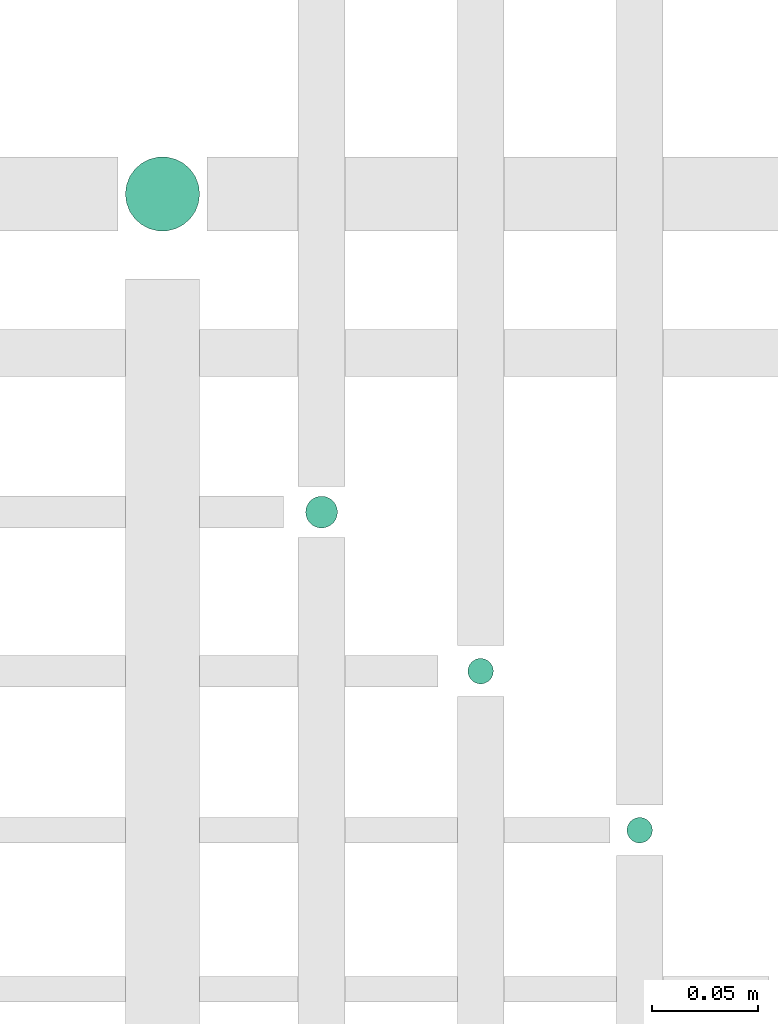
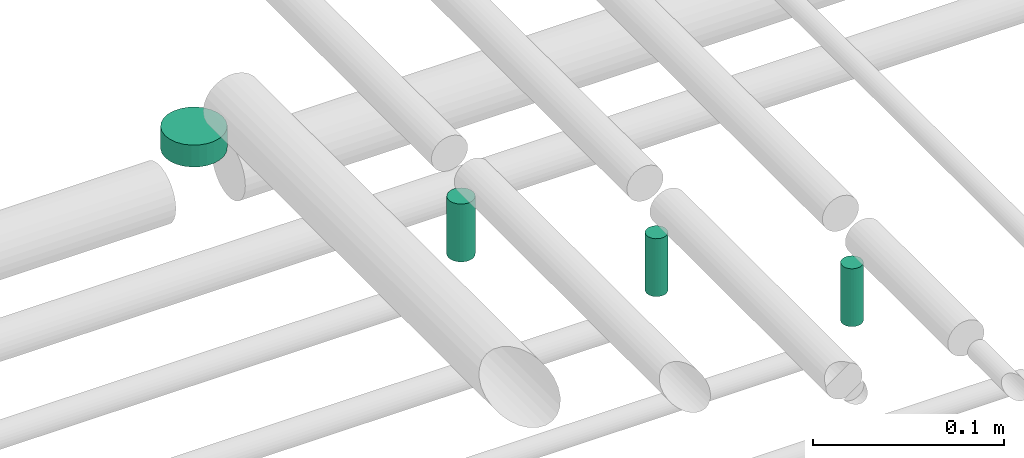
# One storey, part 60 of 65: 4 flow segments.
"""IFC2X3 building model written with IfcOpenShell, lengths in millimetres."""

from ifc_helpers import new_model, entity, si_unit, converted_unit, derived_unit, direction, frame, origin, origin_2d_with_axis, place, context, subcontext, project, spatial, circle, extrude, type_object, element, save


model = new_model("IFC2X3")

# Units and contexts
model_context = context("Model", 3, precision=0.01, world=origin(), true_north=direction((6.12303176911189e-17, 1.0)))
body_context = subcontext(model_context, "Body", "Model", "MODEL_VIEW")
ifc_project = project(units=[si_unit("LENGTHUNIT", "METRE", prefix="MILLI"), si_unit("AREAUNIT", "SQUARE_METRE"), si_unit("VOLUMEUNIT", "CUBIC_METRE"), converted_unit("PLANEANGLEUNIT", "DEGREE", entity("IfcRatioMeasure", 0.0174532925199433), si_unit("PLANEANGLEUNIT", "RADIAN"), dimensions=[0, 0, 0, 0, 0, 0, 0]), si_unit("MASSUNIT", "GRAM", prefix="KILO"), derived_unit("MASSDENSITYUNIT", [(si_unit("MASSUNIT", "GRAM", prefix="KILO"), 1), (si_unit("LENGTHUNIT", "METRE"), -3)]), derived_unit("MOMENTOFINERTIAUNIT", [(si_unit("LENGTHUNIT", "METRE"), 4)]), si_unit("TIMEUNIT", "SECOND"), si_unit("FREQUENCYUNIT", "HERTZ"), si_unit("THERMODYNAMICTEMPERATUREUNIT", "DEGREE_CELSIUS"), derived_unit("THERMALTRANSMITTANCEUNIT", [(si_unit("MASSUNIT", "GRAM", prefix="KILO"), 1), (si_unit("THERMODYNAMICTEMPERATUREUNIT", "KELVIN"), -1), (si_unit("TIMEUNIT", "SECOND"), -3)]), derived_unit("VOLUMETRICFLOWRATEUNIT", [(si_unit("LENGTHUNIT", "METRE"), 3), (si_unit("TIMEUNIT", "SECOND"), -1)]), derived_unit("MASSFLOWRATEUNIT", [(si_unit("MASSUNIT", "GRAM", prefix="KILO"), 1), (si_unit("TIMEUNIT", "SECOND"), -1)]), derived_unit("ROTATIONALFREQUENCYUNIT", [(si_unit("TIMEUNIT", "SECOND"), -1)]), si_unit("ELECTRICCURRENTUNIT", "AMPERE"), si_unit("ELECTRICVOLTAGEUNIT", "VOLT"), si_unit("POWERUNIT", "WATT"), si_unit("FORCEUNIT", "NEWTON", prefix="KILO"), si_unit("ILLUMINANCEUNIT", "LUX"), si_unit("LUMINOUSFLUXUNIT", "LUMEN"), si_unit("LUMINOUSINTENSITYUNIT", "CANDELA"), derived_unit("USERDEFINED", [(si_unit("MASSUNIT", "GRAM", prefix="KILO"), -1), (si_unit("LENGTHUNIT", "METRE"), -2), (si_unit("TIMEUNIT", "SECOND"), 3), (si_unit("LUMINOUSFLUXUNIT", "LUMEN"), 1)]), derived_unit("LINEARVELOCITYUNIT", [(si_unit("LENGTHUNIT", "METRE"), 1), (si_unit("TIMEUNIT", "SECOND"), -1)]), si_unit("PRESSUREUNIT", "PASCAL"), derived_unit("USERDEFINED", [(si_unit("LENGTHUNIT", "METRE"), -2), (si_unit("MASSUNIT", "GRAM", prefix="KILO"), 1), (si_unit("TIMEUNIT", "SECOND"), -2)]), derived_unit("LINEARFORCEUNIT", [(si_unit("MASSUNIT", "GRAM", prefix="KILO"), 1), (si_unit("LENGTHUNIT", "METRE"), 1), (si_unit("TIMEUNIT", "SECOND"), -2), (si_unit("LENGTHUNIT", "METRE"), -1)]), derived_unit("PLANARFORCEUNIT", [(si_unit("MASSUNIT", "GRAM", prefix="KILO"), 1), (si_unit("LENGTHUNIT", "METRE"), 1), (si_unit("TIMEUNIT", "SECOND"), -2), (si_unit("LENGTHUNIT", "METRE"), -2)])], contexts=[model_context])

# Site, building, storey
site_placement = place(None, frame((0.0, -0.00077364408347762, 0.0)))
site = spatial("IfcSite", under=ifc_project, at=site_placement, CompositionType="ELEMENT")
building_placement = place(site_placement, origin())
building = spatial("IfcBuilding", under=site, at=building_placement, CompositionType="ELEMENT")
storey_placement = place(building_placement, frame((0.0, 0.0, 19800.0)))
storey = spatial("IfcBuildingStorey", under=building, at=storey_placement, CompositionType="ELEMENT", Elevation=19800.0)

# Flow segments
pipe_segment_type = type_object("IfcPipeSegmentType", PredefinedType="NOTDEFINED")
flow_segment_1_placement = place(storey_placement, frame((63690.9640720084, 8680.90493375773, 2496.0)))
element("IfcFlowSegment", 1, at=flow_segment_1_placement, inside=storey, type_object=pipe_segment_type, context=body_context, shape_type="SweptSolid", body=[
    extrude(circle(Radius=17.5, at=origin_2d_with_axis()), frame((19.0952722359119, 19.0952722359163, 0.0), z_axis=(0.0, 0.0, 1.0), x_axis=(-1.0, 0.0, 0.0)), (0.0, 0.0, 1.0), 14.0000000000011),
])
flow_segment_2_placement = place(storey_placement, frame((63775.9640720084, 8540.90493375779, 2493.0)))
element("IfcFlowSegment", 2, at=flow_segment_2_placement, inside=storey, type_object=pipe_segment_type, context=body_context, shape_type="SweptSolid", body=[
    extrude(circle(Radius=7.5, at=origin_2d_with_axis()), frame((9.09527223591419, 9.09527223591636, 0.0)), (0.0, 0.0, 1.0), 36.9999999999439),
])
for number, where in (
    (3, (63852.4640720084, 8467.4049337578, 2489.0)),
    (4, (63927.4640720084, 8392.40493375772, 2489.0)),
):
    element("IfcFlowSegment", number, at=place(storey_placement, frame(where)), inside=storey, type_object=pipe_segment_type, context=body_context, shape_type="SweptSolid", body=[
        extrude(circle(Radius=6.0, at=origin_2d_with_axis()), frame((7.59527223591454, 7.59527223591562, 0.0)), (0.0, 0.0, 1.0), 36.9999999999439),
    ])

save(model, "model.ifc")
